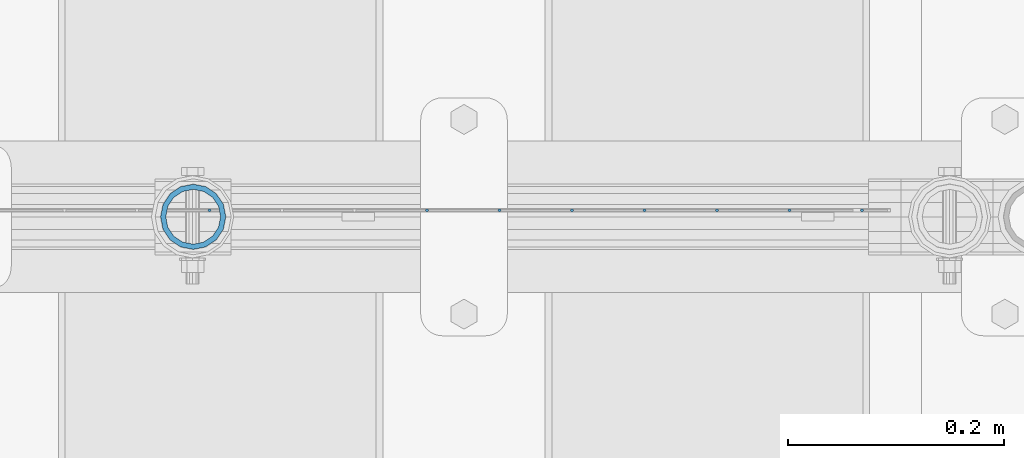
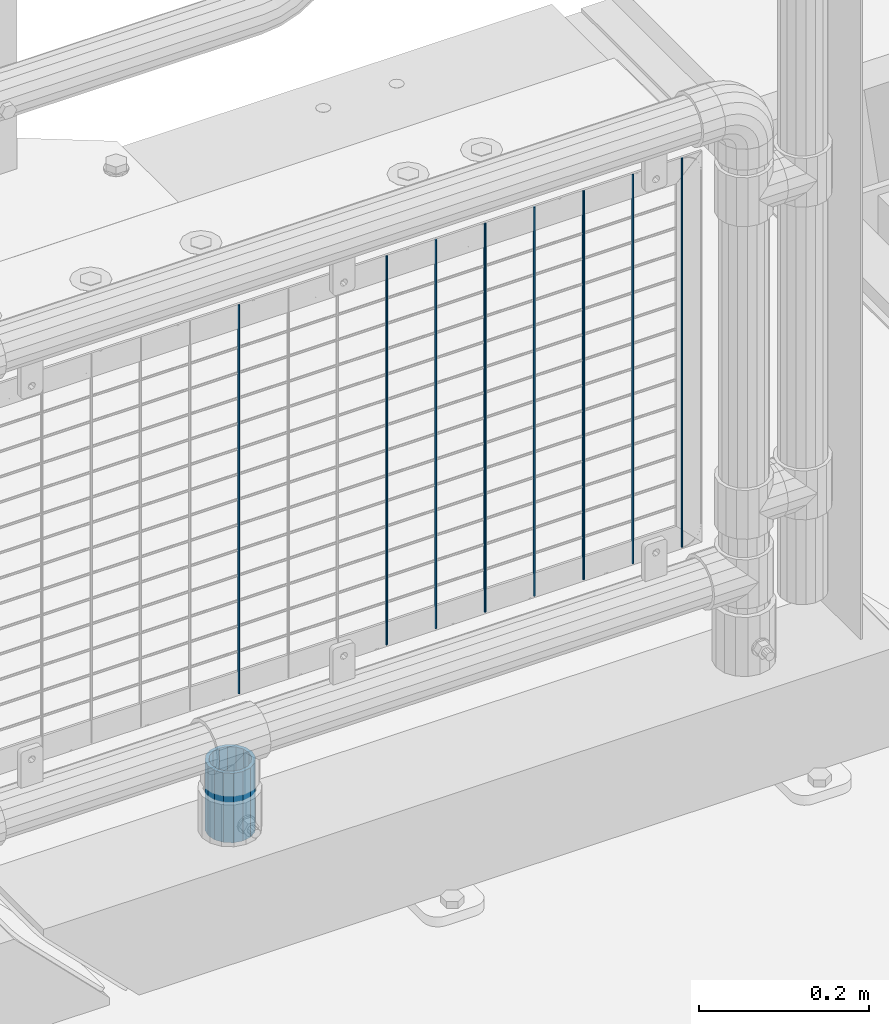
# One storey, part 106 of 242: 9 columns.
"""IFC2X3 building model written with IfcOpenShell, lengths in millimetres."""

from ifc_helpers import new_model, si_unit, frame, origin_with_axes, place, context, subcontext, project, spatial, faceted_brep, material, type_object, element, save


model = new_model("IFC2X3")

# Units and contexts
model_context = context("Model", 3, precision=1e-05, world=origin_with_axes())
body_context = subcontext(model_context, "Body", "Model", "MODEL_VIEW")
ifc_project = project(units=[si_unit("LENGTHUNIT", "METRE", prefix="MILLI"), si_unit("AREAUNIT", "SQUARE_METRE"), si_unit("VOLUMEUNIT", "CUBIC_METRE"), si_unit("MASSUNIT", "GRAM", prefix="KILO"), si_unit("TIMEUNIT", "SECOND"), si_unit("PLANEANGLEUNIT", "RADIAN"), si_unit("SOLIDANGLEUNIT", "STERADIAN"), si_unit("THERMODYNAMICTEMPERATUREUNIT", "DEGREE_CELSIUS"), si_unit("LUMINOUSINTENSITYUNIT", "LUMEN")], contexts=[model_context])

# Site, building, storey
site_placement = place(None, origin_with_axes())
site = spatial("IfcSite", under=ifc_project, at=site_placement, CompositionType="ELEMENT")
building_placement = place(site_placement, origin_with_axes())
building = spatial("IfcBuilding", under=site, at=building_placement, Name="Standard", CompositionType="ELEMENT")
storey_placement = place(building_placement, origin_with_axes())
storey = spatial("IfcBuildingStorey", under=building, at=storey_placement, Name="Undefined", CompositionType="ELEMENT", Elevation=0.0)

# Columns
ifc_material_1 = material()
column_type_1 = type_object("IfcColumnType", PredefinedType="NOTDEFINED")
column_placement = place(storey_placement, frame((-23355.39, -19335.5, 168.02), z_axis=(-1.0, 0.0, 0.0), x_axis=(0.0, 0.0, 1.0)))
element("IfcColumn", 1, at=column_placement, inside=storey, type_object=column_type_1, material=ifc_material_1, context=body_context, shape_type="Brep", body=[
    faceted_brep([(0.0, -25.3499999999985, 0.0), (0.0, -23.4203461491597, 9.70102501045403), (100.0, -23.4203461491597, 9.70102501045403), (100.0, -25.3499999999985, 0.0), (0.0, -17.9251569030785, 17.9251569030785), (100.0, -17.9251569030785, 17.9251569030785), (0.0, -9.70102501045403, 23.4203461491597), (100.0, -9.70102501045403, 23.4203461491597), (0.0, 0.0, 25.3499999999985), (100.0, 0.0, 25.3499999999985), (0.0, 9.70102501045403, 23.4203461491597), (100.0, 9.70102501045403, 23.4203461491597), (0.0, 17.9251569030785, 17.9251569030785), (100.0, 17.9251569030785, 17.9251569030785), (0.0, 23.4203461491597, 9.70102501045403), (100.0, 23.4203461491597, 9.70102501045403), (0.0, 25.3499999999985, 0.0), (100.0, 25.3499999999985, 0.0), (0.0, 23.4203461491597, -9.70102501045403), (100.0, 23.4203461491597, -9.70102501045403), (0.0, 17.9251569030785, -17.9251569030785), (100.0, 17.9251569030785, -17.9251569030785), (0.0, 9.70102501045403, -23.4203461491597), (100.0, 9.70102501045403, -23.4203461491597), (0.0, 0.0, -25.3499999999985), (100.0, 0.0, -25.3499999999985), (0.0, -9.70102501045403, -23.4203461491597), (100.0, -9.70102501045403, -23.4203461491597), (0.0, -17.9251569030785, -17.9251569030785), (100.0, -17.9251569030785, -17.9251569030785), (0.0, -23.4203461491597, -9.70102501045403), (100.0, -23.4203461491597, -9.70102501045403), (0.0, -30.1500000000015, 0.0), (0.0, -27.8549679052157, -11.5379054858058), (100.0, -27.8549679052157, -11.5379054858058), (100.0, -30.1500000000015, 0.0), (0.0, -21.3192694527752, -21.3192694527752), (100.0, -21.3192694527752, -21.3192694527752), (0.0, -11.5379054858058, -27.8549679052157), (100.0, -11.5379054858058, -27.8549679052157), (0.0, 0.0, -30.1500000000015), (100.0, 0.0, -30.1500000000015), (0.0, 11.5379054858058, -27.8549679052157), (100.0, 11.5379054858058, -27.8549679052157), (0.0, 21.3192694527752, -21.3192694527752), (100.0, 21.3192694527752, -21.3192694527752), (0.0, 27.8549679052157, -11.5379054858058), (100.0, 27.8549679052157, -11.5379054858058), (0.0, 30.1500000000015, 0.0), (100.0, 30.1500000000015, 0.0), (0.0, 27.8549679052157, 11.5379054858058), (100.0, 27.8549679052157, 11.5379054858058), (0.0, 21.3192694527752, 21.3192694527752), (100.0, 21.3192694527752, 21.3192694527752), (0.0, 11.5379054858058, 27.8549679052157), (100.0, 11.5379054858058, 27.8549679052157), (0.0, 0.0, 30.1500000000015), (100.0, 0.0, 30.1500000000015), (0.0, -11.5379054858058, 27.8549679052157), (100.0, -11.5379054858058, 27.8549679052157), (0.0, -21.3192694527752, 21.3192694527752), (100.0, -21.3192694527752, 21.3192694527752), (0.0, -27.8549679052157, 11.5379054858058), (100.0, -27.8549679052157, 11.5379054858058)], [[[0, 1, 2, 3]], [[1, 4, 5, 2]], [[4, 6, 7, 5]], [[6, 8, 9, 7]], [[8, 10, 11, 9]], [[10, 12, 13, 11]], [[12, 14, 15, 13]], [[14, 16, 17, 15]], [[16, 18, 19, 17]], [[18, 20, 21, 19]], [[20, 22, 23, 21]], [[22, 24, 25, 23]], [[24, 26, 27, 25]], [[26, 28, 29, 27]], [[28, 30, 31, 29]], [[30, 0, 3, 31]], [[32, 33, 34, 35]], [[33, 36, 37, 34]], [[36, 38, 39, 37]], [[38, 40, 41, 39]], [[40, 42, 43, 41]], [[42, 44, 45, 43]], [[44, 46, 47, 45]], [[46, 48, 49, 47]], [[48, 50, 51, 49]], [[50, 52, 53, 51]], [[52, 54, 55, 53]], [[54, 56, 57, 55]], [[56, 58, 59, 57]], [[58, 60, 61, 59]], [[60, 62, 63, 61]], [[62, 32, 35, 63]], [[37, 39, 41, 43, 45, 47, 49, 51, 53, 55, 57, 59, 61, 63, 35, 34], [5, 7, 9, 11, 13, 15, 17, 19, 21, 23, 25, 27, 29, 31, 3, 2]], [[62, 60, 58, 56, 54, 52, 50, 48, 46, 44, 42, 40, 38, 36, 33, 32], [30, 28, 26, 24, 22, 20, 18, 16, 14, 12, 10, 8, 6, 4, 1, 0]]]),
])
ifc_material_2 = material(Name="Misc_Undefined")
column_type_2 = type_object("IfcColumnType", Name="D3", PredefinedType="NOTDEFINED")
for number, where, z_axis, x_axis in (
    (2, (-22736.9979999999, -19329.5002158991, 353.02), (-1.0, 0.0, 0.0), (0.0, 0.0, 1.0)),
    (3, (-22804.0259999999, -19329.5002016903, 353.02), (-1.0, 0.0, 0.0), (0.0, 0.0, 1.0)),
    (4, (-22871.0539999999, -19329.5001874815, 353.02), (-1.0, 0.0, 0.0), (0.0, 0.0, 1.0)),
    (5, (-22938.0819999999, -19329.5001732727, 353.02), (-1.0, 0.0, 0.0), (0.0, 0.0, 1.0)),
    (6, (-23005.1099999999, -19329.5001590638, 353.02), (-1.0, 0.0, 0.0), (0.0, 0.0, 1.0)),
    (7, (-23072.1379999999, -19329.500144855, 353.02), (-1.0, 0.0, 0.0), (0.0, 0.0, 1.0)),
    (8, (-23139.1659999999, -19329.5001306462, 353.02), (-1.0, 0.0, 0.0), (0.0, 0.0, 1.0)),
    (9, (-23340.2499999999, -19329.5000880198, 353.02), (-1.0, 0.0, 0.0), (0.0, 0.0, 1.0)),
):
    element("IfcColumn", number, at=place(storey_placement, frame(where, z_axis=z_axis, x_axis=x_axis)), inside=storey, type_object=column_type_2, material=ifc_material_2, ObjectType="D3", context=body_context, shape_type="Brep", body=[
        faceted_brep([(0.0, -1.50000000000364, 0.0), (-3.63797880709171e-12, -0.750000000003638, -1.29903810567669), (560.0, -0.75, -1.29903810567703), (560.0, -1.5, 0.0), (0.0, 0.749999999996362, -1.29903810567669), (560.0, 0.75, -1.29903810567703), (-3.63797880709171e-12, 1.49999999999636, 0.0), (560.0, 1.5, 0.0), (0.0, 0.749999999996362, 1.29903810567669), (560.0, 0.75, 1.29903810567703), (-3.63797880709171e-12, -0.750000000003638, 1.29903810567669), (560.0, -0.75, 1.29903810567703)], [[[0, 1, 2, 3]], [[1, 4, 5, 2]], [[4, 6, 7, 5]], [[6, 8, 9, 7]], [[8, 10, 11, 9]], [[10, 0, 3, 11]], [[5, 7, 9, 11, 3, 2]], [[10, 8, 6, 4, 1, 0]]]),
    ])

save(model, "model.ifc")
